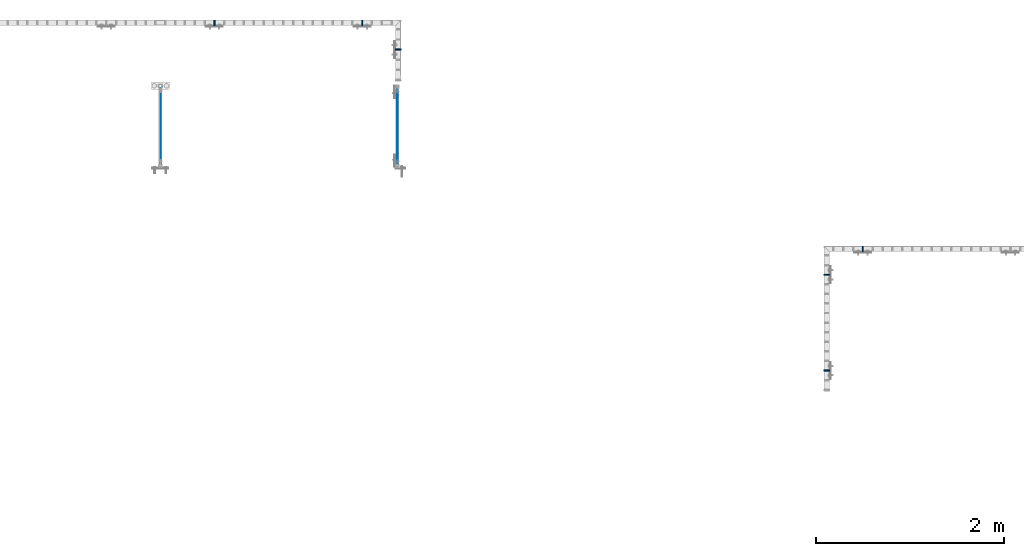
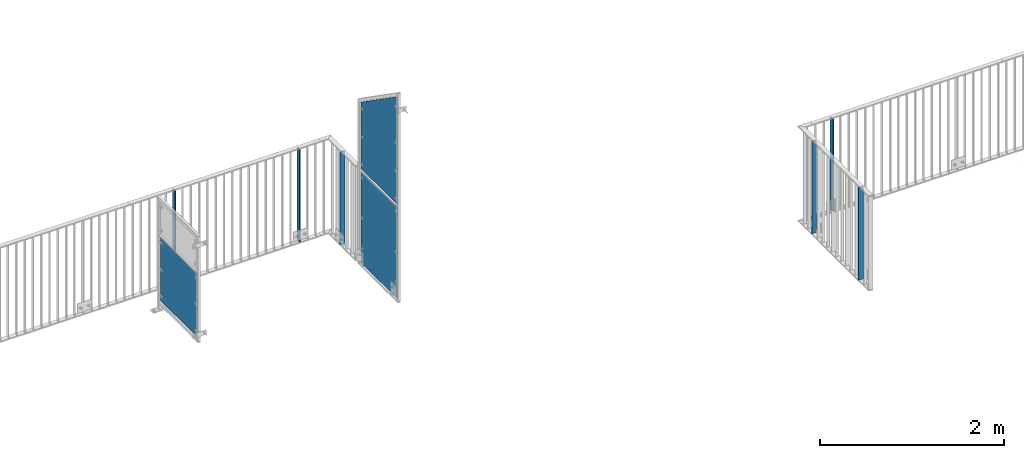
# One storey, part 44 of 156: 9 plates, 7 elements without a shape of their own.
"""IFC2X3 building model written with IfcOpenShell, lengths in millimetres."""

from ifc_helpers import new_model, si_unit, frame, origin_with_axes, origin_2d_with_axis, place, context, subcontext, project, spatial, rectangle, extrude, clip, halfspace, material, type_object, element, aggregate, save


model = new_model("IFC2X3")

# Units and contexts
model_context = context("Model", 3, precision=1e-05, world=origin_with_axes())
body_context = subcontext(model_context, "Body", "Model", "MODEL_VIEW")
ifc_project = project(units=[si_unit("LENGTHUNIT", "METRE", prefix="MILLI"), si_unit("AREAUNIT", "SQUARE_METRE"), si_unit("VOLUMEUNIT", "CUBIC_METRE"), si_unit("MASSUNIT", "GRAM", prefix="KILO"), si_unit("TIMEUNIT", "SECOND"), si_unit("PLANEANGLEUNIT", "RADIAN"), si_unit("SOLIDANGLEUNIT", "STERADIAN"), si_unit("THERMODYNAMICTEMPERATUREUNIT", "DEGREE_CELSIUS"), si_unit("LUMINOUSINTENSITYUNIT", "LUMEN")], contexts=[model_context])

# Site, building, storey
site_placement = place(None, origin_with_axes())
site = spatial("IfcSite", under=ifc_project, at=site_placement, CompositionType="ELEMENT")
building_placement = place(site_placement, origin_with_axes())
building = spatial("IfcBuilding", under=site, at=building_placement, Name="Undefined", CompositionType="ELEMENT")
storey_placement = place(building_placement, origin_with_axes())
storey = spatial("IfcBuildingStorey", under=building, at=storey_placement, Name="Undefined", CompositionType="ELEMENT", Elevation=0.0)

# Assembly, plate
assembly_1_placement = place(storey_placement, origin_with_axes())
assembly_1 = element("IfcElementAssembly", 1, at=assembly_1_placement, inside=storey, AssemblyPlace="NOTDEFINED", PredefinedType="RIGID_FRAME")
ifc_material = material(Name="STEEL/S235JR")
plate_type_1 = type_object("IfcPlateType", PredefinedType="NOTDEFINED")
plate_1_placement = place(assembly_1_placement, frame((24974.6454415188, 24057.9916060596, 3980.00000000003), z_axis=(0.0, -1.0, 0.0), x_axis=(0.0, 0.0, -1.0)))
plate_1 = element("IfcPlate", 2, at=plate_1_placement, type_object=plate_type_1, material=ifc_material, context=body_context, shape_type="SweptSolid", body=[
    extrude(rectangle(XDim=12.0, YDim=60.0, at=origin_2d_with_axis()), frame((1230.0, 0.0, 0.0), z_axis=(-1.0, 0.0, 0.0), x_axis=(0.0, -1.0, 0.0)), (0.0, 0.0, 1.0), 1230.0),
])

assembly_2_placement = place(storey_placement, origin_with_axes())
assembly_2 = element("IfcElementAssembly", 3, at=assembly_2_placement, inside=storey, AssemblyPlace="NOTDEFINED", PredefinedType="RIGID_FRAME")
plate_2_placement = place(assembly_2_placement, frame((26924.9982838167, 23774.1503835178, 3980.00000000003), z_axis=(-1.0, 0.0, 0.0), x_axis=(0.0, 0.0, -1.0)))
plate_2 = element("IfcPlate", 4, at=plate_2_placement, type_object=plate_type_1, material=ifc_material, context=body_context, shape_type="SweptSolid", body=[
    extrude(rectangle(XDim=12.0, YDim=60.0, at=origin_2d_with_axis()), frame((1230.0, 0.0, 0.0), z_axis=(-1.0, 0.0, 0.0), x_axis=(0.0, -1.0, 0.0)), (0.0, 0.0, 1.0), 1230.0),
])
aggregate(assembly_2, [plate_2])

# Plate
plate_3_placement = place(assembly_1_placement, frame((26541.6668934283, 24057.9916060596, 3980.00000000003), z_axis=(0.0, -1.0, 0.0), x_axis=(0.0, 0.0, -1.0)))
plate_3 = element("IfcPlate", 5, at=plate_3_placement, type_object=plate_type_1, material=ifc_material, context=body_context, shape_type="SweptSolid", body=[
    extrude(rectangle(XDim=12.0, YDim=60.0, at=origin_2d_with_axis()), frame((1230.0, 0.0, 0.0), z_axis=(-1.0, 0.0, 0.0), x_axis=(0.0, -1.0, 0.0)), (0.0, 0.0, 1.0), 1230.0),
])

aggregate(assembly_1, [plate_1, plate_3])

# Assembly, plate
assembly_3_placement = place(storey_placement, origin_with_axes())
assembly_3 = element("IfcElementAssembly", 6, at=assembly_3_placement, inside=storey, AssemblyPlace="NOTDEFINED", PredefinedType="RIGID_FRAME")
plate_4_placement = place(assembly_3_placement, frame((31474.9983592497, 20366.5813952275, 3980.00000000003), z_axis=(1.0, 0.0, 0.0), x_axis=(0.0, 0.0, -1.0)))
plate_4 = element("IfcPlate", 7, at=plate_4_placement, type_object=plate_type_1, material=ifc_material, context=body_context, shape_type="SweptSolid", body=[
    extrude(rectangle(XDim=12.0, YDim=60.0, at=origin_2d_with_axis()), frame((1230.0, 0.0, 0.0), z_axis=(-1.0, 0.0, 0.0), x_axis=(0.0, -1.0, 0.0)), (0.0, 0.0, 1.0), 1230.0),
])

assembly_4_placement = place(storey_placement, origin_with_axes())
assembly_4 = element("IfcElementAssembly", 8, at=assembly_4_placement, inside=storey, AssemblyPlace="NOTDEFINED", PredefinedType="RIGID_FRAME")
plate_5_placement = place(assembly_4_placement, frame((31858.3187312877, 21657.9919875293, 3980.00000000003), z_axis=(0.0, -1.0, 0.0), x_axis=(0.0, 0.0, -1.0)))
plate_5 = element("IfcPlate", 9, at=plate_5_placement, type_object=plate_type_1, material=ifc_material, context=body_context, shape_type="SweptSolid", body=[
    extrude(rectangle(XDim=12.0, YDim=60.0, at=origin_2d_with_axis()), frame((1230.0, 0.0, 0.0), z_axis=(-1.0, 0.0, 0.0), x_axis=(0.0, -1.0, 0.0)), (0.0, 0.0, 1.0), 1230.0),
])
aggregate(assembly_4, [plate_5])

# Plate
plate_6_placement = place(assembly_3_placement, frame((31474.9983592497, 21384.4307649875, 3980.00000000003), z_axis=(1.0, 0.0, 0.0), x_axis=(0.0, 0.0, -1.0)))
plate_6 = element("IfcPlate", 10, at=plate_6_placement, type_object=plate_type_1, material=ifc_material, context=body_context, shape_type="SweptSolid", body=[
    extrude(rectangle(XDim=12.0, YDim=60.0, at=origin_2d_with_axis()), frame((1230.0, 0.0, 0.0), z_axis=(-1.0, 0.0, 0.0), x_axis=(0.0, -1.0, 0.0)), (0.0, 0.0, 1.0), 1230.0),
])

aggregate(assembly_3, [plate_4, plate_6])

# Assembly, plate
assembly_5_placement = place(storey_placement, origin_with_axes())
assembly_5 = element("IfcElementAssembly", 11, at=assembly_5_placement, inside=storey, AssemblyPlace="NOTDEFINED", PredefinedType="RIGID_FRAME")
plate_type_2 = type_object("IfcPlateType", PredefinedType="NOTDEFINED")
plate_7_placement = place(assembly_5_placement, frame((24404.0, 22562.9559575678, 3550.0), z_axis=(0.0, 0.0, 1.0), x_axis=(0.0, 1.0, 0.0)))
plate_7 = element("IfcPlate", 12, at=plate_7_placement, type_object=plate_type_2, material=ifc_material, context=body_context, shape_type="SweptSolid", body=[
    extrude(rectangle(XDim=3.0, YDim=850.0, at=origin_2d_with_axis()), frame((800.050991195178, 0.0, 0.0), z_axis=(-1.0, 0.0, 0.0), x_axis=(0.0, -1.0, 0.0)), (0.0, 0.0, 1.0), 800.05),
])
aggregate(assembly_5, [plate_7])

assembly_6_placement = place(storey_placement, origin_with_axes())
assembly_6 = element("IfcElementAssembly", 13, at=assembly_6_placement, inside=storey, AssemblyPlace="NOTDEFINED", PredefinedType="RIGID_FRAME")
plate_type_3 = type_object("IfcPlateType", PredefinedType="NOTDEFINED")
plate_8_placement = place(assembly_6_placement, frame((26918.9961242676, 22563.0102746575, 3365.0), z_axis=(0.0, 0.0, 1.0), x_axis=(0.0, 1.0, 0.0)))
plate_8 = element("IfcPlate", 14, at=plate_8_placement, type_object=plate_type_3, material=ifc_material, context=body_context, shape_type="SweptSolid", body=[
    extrude(rectangle(XDim=3.0, YDim=1220.0, at=origin_2d_with_axis()), frame((790.000991195178, 0.0, 0.0), z_axis=(-1.0, 0.0, 0.0), x_axis=(0.0, -1.0, 0.0)), (0.0, 0.0, 1.0), 790.0),
])
aggregate(assembly_6, [plate_8])

assembly_7_placement = place(storey_placement, origin_with_axes())
assembly_7 = element("IfcElementAssembly", 15, at=assembly_7_placement, inside=storey, AssemblyPlace="NOTDEFINED", PredefinedType="RIGID_FRAME")
plate_9_placement = place(assembly_7_placement, frame((26918.9961242676, 22563.0033416748, 4730.00076289195), z_axis=(0.0, 0.0, 1.0), x_axis=(0.0, 1.0, 0.0)))
plate_9 = element("IfcPlate", 16, at=plate_9_placement, type_object=plate_type_3, material=ifc_material, context=body_context, shape_type="Clipping", body=[
    clip(extrude(rectangle(XDim=3.0, YDim=1450.0, at=origin_2d_with_axis()), frame((790.000991195178, 0.0, 0.0), z_axis=(-1.0, 0.0, 0.0), x_axis=(0.0, -1.0, 0.0)), (0.0, 0.0, 1.0), 790.0), halfspace(frame((2059.65165642691, -1.5, -729.1), z_axis=(0.573576519196191, 0.0, 0.819151986280191), x_axis=(-0.819151986280191, 0.0, 0.573576519196191)), False)),
])
aggregate(assembly_7, [plate_9])

save(model, "model.ifc")
